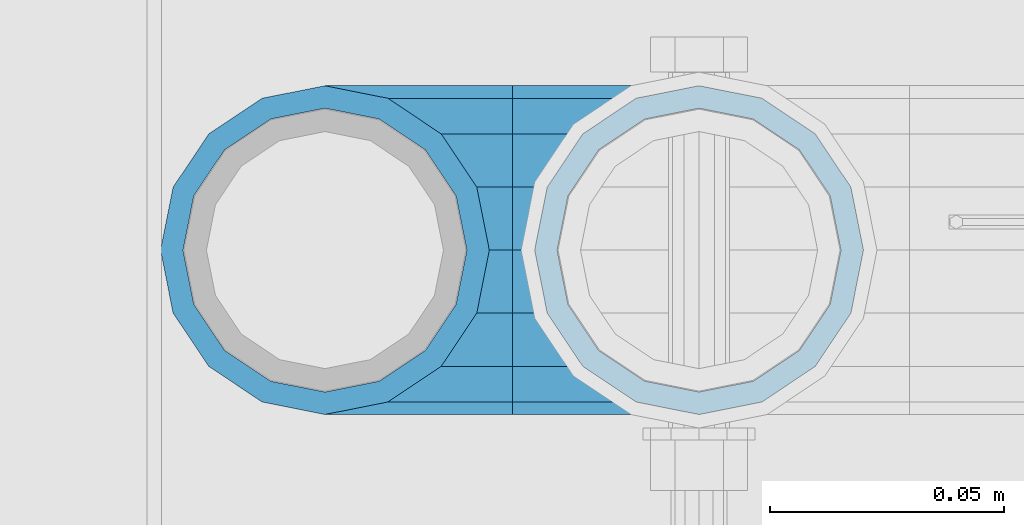
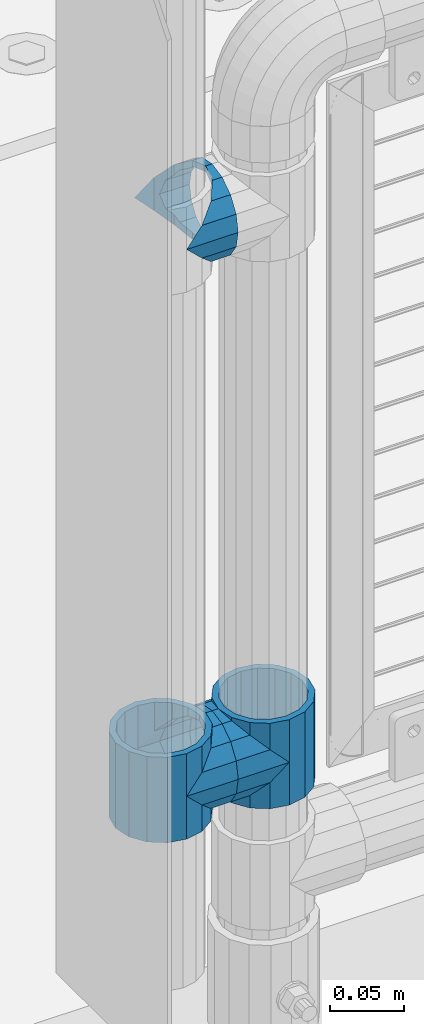
# One storey, part 133 of 219: 5 beams.
"""IFC2X3 building model written with IfcOpenShell, lengths in millimetres."""

from ifc_helpers import new_model, si_unit, frame, origin_with_axes, place, context, subcontext, project, spatial, faceted_brep, material, type_object, element, save


model = new_model("IFC2X3")

# Units and contexts
model_context = context("Model", 3, precision=1e-05, world=origin_with_axes())
body_context = subcontext(model_context, "Body", "Model", "MODEL_VIEW")
ifc_project = project(units=[si_unit("LENGTHUNIT", "METRE", prefix="MILLI"), si_unit("AREAUNIT", "SQUARE_METRE"), si_unit("VOLUMEUNIT", "CUBIC_METRE"), si_unit("MASSUNIT", "GRAM", prefix="KILO"), si_unit("TIMEUNIT", "SECOND"), si_unit("PLANEANGLEUNIT", "RADIAN"), si_unit("SOLIDANGLEUNIT", "STERADIAN"), si_unit("THERMODYNAMICTEMPERATUREUNIT", "DEGREE_CELSIUS"), si_unit("LUMINOUSINTENSITYUNIT", "LUMEN")], contexts=[model_context])

# Site, building, storey
site_placement = place(None, origin_with_axes())
site = spatial("IfcSite", under=ifc_project, at=site_placement, CompositionType="ELEMENT")
building_placement = place(site_placement, origin_with_axes())
building = spatial("IfcBuilding", under=site, at=building_placement, Name="Standard", CompositionType="ELEMENT")
storey_placement = place(building_placement, origin_with_axes())
storey = spatial("IfcBuildingStorey", under=building, at=storey_placement, Name="Undefined", CompositionType="ELEMENT", Elevation=0.0)

# Beams
ifc_material = material(Name="Misc_Undefined")
beam_type = type_object("IfcBeamType", PredefinedType="NOTDEFINED")
beam_1_placement = place(storey_placement, frame((541.0, 31664.5, 398.670000000001), z_axis=(0.0, -1.0, 0.0), x_axis=(1.0, 0.0, 0.0)))
element("IfcBeam", 1, at=beam_1_placement, inside=storey, type_object=beam_type, material=ifc_material, context=body_context, shape_type="Brep", body=[
    faceted_brep([(0.0, 0.0, -35.1500000000015), (13.4513226476338, -13.4513226476329, -32.4743655677703), (13.4513226476338, 13.4513226476329, -32.4743655677703), (32.4743655677721, 32.4743655677717, 13.4513226476338), (32.4743655677721, 26.8123795176755, 13.4513226476338), (27.1226768591096, 21.4606908090117, 21.46069080901), (24.8548033587067, 16.3810424080078, 24.8548033587067), (24.8548033587067, 24.8548033587072, 24.8548033587067), (0.0, 0.0, 35.1500000000015), (13.4513226476338, 13.4513226476329, 32.4743655677703), (13.4513226476338, -13.4513226476329, 32.4743655677703), (20.0882031229849, 11.6144421722805, 28.0397438117179), (16.6306603983739, 0.0, 30.3499999999985), (20.0882031229849, -11.6144421722805, 28.0397438117179), (24.8548033587067, -16.3810424080013, 24.8548033587067), (24.8548033587067, -24.8548033587072, 24.8548033587067), (27.1226768591096, -21.4606908090117, 21.46069080901), (32.4743655677721, -26.8123795176755, 13.4513226476338), (32.4743655677721, -32.4743655677717, 13.4513226476338), (32.8397438117172, -28.0397438117175, 11.614442172282), (35.1499999999996, -30.35, 0.0), (35.1499999999996, -35.15, 0.0), (32.4743655677721, -26.8123795176712, -13.4513226476338), (32.4743655677721, -32.4743655677717, -13.4513226476338), (32.8397438117172, -28.0397438117175, -11.614442172282), (24.8548033587067, -16.3810424080013, -24.8548033587067), (24.8548033587067, -24.8548033587072, -24.8548033587067), (27.1226768591077, -21.4606908090117, -21.46069080901), (20.0882031229739, -11.6144421722805, -28.0397438117179), (16.6306603983649, 0.0, -30.3499999999985), (20.0882031229739, 11.6144421722805, -28.0397438117179), (24.8548033587067, 16.3810424080013, -24.8548033587067), (24.8548033587067, 24.8548033587072, -24.8548033587067), (27.1226768591077, 21.4606908090117, -21.46069080901), (32.4743655677721, 26.8123795176755, -13.4513226476338), (32.4743655677721, 32.4743655677717, -13.4513226476338), (32.8397438117172, 28.0397438117175, -11.614442172282), (35.1499999999996, 30.35, 0.0), (35.1499999999996, 35.15, 0.0), (32.8397438117172, 28.0397438117175, 11.614442172282), (40.1500000000015, -35.15, 0.0), (40.1500000000015, -32.4743655677717, 13.4513226476338), (40.1500000000015, -24.8548033587072, 24.8548033587067), (40.1500000000015, -13.4513226476329, 32.4743655677703), (40.1500000000015, 0.0, 35.1500000000015), (40.1500000000015, 13.4513226476329, 32.4743655677703), (40.1500000000015, 24.8548033587072, 24.8548033587067), (40.1500000000015, 32.4743655677717, 13.4513226476338), (40.1500000000015, 35.15, 0.0), (40.1500000000015, -24.8548033587072, -24.8548033587067), (40.1500000000015, -32.4743655677717, -13.4513226476338), (40.1500000000015, -13.4513226476329, -32.4743655677703), (40.1500000000015, 0.0, -35.1500000000015), (40.1500000000015, 13.4513226476329, -32.4743655677703), (40.1500000000015, 24.8548033587072, -24.8548033587067), (40.1500000000015, 32.4743655677717, -13.4513226476338), (40.1500000000015, -21.4606908090117, 21.46069080901), (40.1500000000015, -11.6144421722805, 28.0397438117179), (40.1500000000015, 0.0, 30.3499999999985), (40.1500000000015, 11.6144421722805, 28.0397438117179), (40.1500000000015, 21.4606908090117, 21.46069080901), (40.1500000000015, 28.0397438117175, 11.614442172282), (40.1500000000015, 30.35, 0.0), (40.1500000000015, 28.0397438117175, -11.614442172282), (40.1500000000015, 21.4606908090117, -21.46069080901), (40.1500000000015, 11.6144421722805, -28.0397438117179), (40.1500000000015, 0.0, -30.3499999999985), (40.1500000000015, -11.6144421722805, -28.0397438117179), (40.1500000000015, -21.4606908090117, -21.46069080901), (40.1500000000015, -28.0397438117175, -11.614442172282), (40.1500000000015, -30.35, 0.0), (40.1500000000015, -28.0397438117175, 11.614442172282)], [[[0, 1, 2]], [[3, 4, 5, 6, 7]], [[8, 9, 10]], [[7, 6, 11, 12, 13, 14, 15, 10, 9]], [[16, 17, 18, 15, 14]], [[19, 20, 21, 18, 17]], [[22, 23, 21, 20, 24]], [[25, 26, 23, 22, 27]], [[2, 1, 26, 25, 28, 29, 30, 31, 32]], [[32, 31, 33, 34, 35]], [[35, 34, 36, 37, 38]], [[38, 37, 39, 4, 3]], [[40, 41, 18, 21]], [[41, 42, 15, 18]], [[42, 43, 10, 15]], [[43, 44, 8, 10]], [[44, 45, 9, 8]], [[45, 46, 7, 9]], [[46, 47, 3, 7]], [[47, 48, 38, 3]], [[49, 50, 23, 26]], [[51, 49, 26, 1]], [[52, 51, 1, 0]], [[53, 52, 0, 2]], [[54, 53, 2, 32]], [[55, 54, 32, 35]], [[48, 55, 35, 38]], [[50, 40, 21, 23]], [[49, 51, 52, 53, 54, 55, 48, 47, 46, 45, 44, 43, 42, 41, 40, 50], [56, 57, 58, 59, 60, 61, 62, 63, 64, 65, 66, 67, 68, 69, 70, 71]], [[63, 62, 37, 36]], [[33, 64, 63, 36, 34]], [[30, 65, 64, 33, 31]], [[66, 65, 30, 29]], [[67, 66, 29, 28]], [[68, 67, 28, 25, 27]], [[69, 68, 27, 22, 24]], [[70, 69, 24, 20]], [[71, 70, 20, 19]], [[16, 56, 71, 19, 17]], [[13, 57, 56, 16, 14]], [[58, 57, 13, 12]], [[59, 58, 12, 11]], [[60, 59, 11, 6, 5]], [[61, 60, 5, 4, 39]], [[62, 61, 39, 37]]]),
])
beam_2_placement = place(storey_placement, frame((621.0, 31664.5, 398.670000000001), z_axis=(0.0, 1.0, 0.0), x_axis=(-1.0, 0.0, 0.0)))
element("IfcBeam", 2, at=beam_2_placement, inside=storey, type_object=beam_type, material=ifc_material, context=body_context, shape_type="Brep", body=[
    faceted_brep([(0.0, 0.0, -35.1500000000015), (13.4513226476338, -13.4513226476329, -32.4743655677703), (13.4513226476338, 13.4513226476329, -32.4743655677703), (27.1226768591096, -21.4606908090117, 21.46069080901), (32.4743655677721, -26.8123795176755, 13.4513226476338), (32.4743655677721, -32.4743655677717, 13.4513226476338), (24.8548033587067, -24.8548033587072, 24.8548033587067), (24.8548033587067, -16.3810424080013, 24.8548033587067), (32.8397438117172, -28.0397438117175, 11.614442172282), (35.1499999999996, -30.35, 0.0), (35.1499999999996, -35.15, 0.0), (32.4743655677721, -26.8123795176712, -13.4513226476338), (32.4743655677721, -32.4743655677717, -13.4513226476338), (32.8397438117172, -28.0397438117175, -11.614442172282), (24.8548033587067, -16.3810424080013, -24.8548033587067), (24.8548033587067, -24.8548033587072, -24.8548033587067), (27.1226768591077, -21.4606908090117, -21.46069080901), (20.0882031229739, -11.6144421722805, -28.0397438117179), (16.6306603983649, 0.0, -30.3499999999985), (20.0882031229739, 11.6144421722805, -28.0397438117179), (24.8548033587067, 16.3810424080013, -24.8548033587067), (24.8548033587067, 24.8548033587072, -24.8548033587067), (27.1226768591077, 21.4606908090117, -21.46069080901), (32.4743655677721, 26.8123795176755, -13.4513226476338), (32.4743655677721, 32.4743655677717, -13.4513226476338), (32.8397438117172, 28.0397438117175, -11.614442172282), (35.1499999999996, 30.35, 0.0), (35.1499999999996, 35.15, 0.0), (32.8397438117172, 28.0397438117175, 11.614442172282), (32.4743655677721, 26.8123795176755, 13.4513226476338), (32.4743655677721, 32.4743655677717, 13.4513226476338), (27.1226768591096, 21.4606908090117, 21.46069080901), (24.8548033587067, 16.3810424080078, 24.8548033587067), (24.8548033587067, 24.8548033587072, 24.8548033587067), (0.0, 0.0, 35.1500000000015), (13.4513226476338, 13.4513226476329, 32.4743655677703), (13.4513226476338, -13.4513226476329, 32.4743655677703), (20.0882031229849, 11.6144421722805, 28.0397438117179), (16.6306603983739, 0.0, 30.3499999999985), (20.0882031229849, -11.6144421722805, 28.0397438117179), (40.1500000000015, -35.15, 0.0), (40.1500000000015, -32.4743655677717, 13.4513226476338), (40.1500000000015, -24.8548033587072, 24.8548033587067), (40.1500000000015, -13.4513226476329, 32.4743655677703), (40.1500000000015, 0.0, 35.1500000000015), (40.1500000000015, -24.8548033587072, -24.8548033587067), (40.1500000000015, -32.4743655677717, -13.4513226476338), (40.1500000000015, -13.4513226476329, -32.4743655677703), (40.1500000000015, 0.0, -35.1500000000015), (40.1500000000015, 13.4513226476329, -32.4743655677703), (40.1500000000015, 24.8548033587072, -24.8548033587067), (40.1500000000015, 32.4743655677717, -13.4513226476338), (40.1500000000015, 35.15, 0.0), (40.1500000000015, 32.4743655677717, 13.4513226476338), (40.1500000000015, 24.8548033587072, 24.8548033587067), (40.1500000000015, 13.4513226476329, 32.4743655677703), (40.1500000000015, -21.4606908090117, 21.46069080901), (40.1500000000015, -11.6144421722805, 28.0397438117179), (40.1500000000015, 0.0, 30.3499999999985), (40.1500000000015, 11.6144421722805, 28.0397438117179), (40.1500000000015, 21.4606908090117, 21.46069080901), (40.1500000000015, 28.0397438117175, 11.614442172282), (40.1500000000015, 30.35, 0.0), (40.1500000000015, 28.0397438117175, -11.614442172282), (40.1500000000015, 21.4606908090117, -21.46069080901), (40.1500000000015, 11.6144421722805, -28.0397438117179), (40.1500000000015, 0.0, -30.3499999999985), (40.1500000000015, -11.6144421722805, -28.0397438117179), (40.1500000000015, -21.4606908090117, -21.46069080901), (40.1500000000015, -28.0397438117175, -11.614442172282), (40.1500000000015, -30.35, 0.0), (40.1500000000015, -28.0397438117175, 11.614442172282)], [[[0, 1, 2]], [[3, 4, 5, 6, 7]], [[8, 9, 10, 5, 4]], [[11, 12, 10, 9, 13]], [[14, 15, 12, 11, 16]], [[2, 1, 15, 14, 17, 18, 19, 20, 21]], [[21, 20, 22, 23, 24]], [[24, 23, 25, 26, 27]], [[27, 26, 28, 29, 30]], [[30, 29, 31, 32, 33]], [[34, 35, 36]], [[33, 32, 37, 38, 39, 7, 6, 36, 35]], [[40, 41, 5, 10]], [[41, 42, 6, 5]], [[42, 43, 36, 6]], [[43, 44, 34, 36]], [[45, 46, 12, 15]], [[47, 45, 15, 1]], [[48, 47, 1, 0]], [[49, 48, 0, 2]], [[50, 49, 2, 21]], [[51, 50, 21, 24]], [[52, 51, 24, 27]], [[53, 52, 27, 30]], [[54, 53, 30, 33]], [[55, 54, 33, 35]], [[44, 55, 35, 34]], [[46, 40, 10, 12]], [[45, 47, 48, 49, 50, 51, 52, 53, 54, 55, 44, 43, 42, 41, 40, 46], [56, 57, 58, 59, 60, 61, 62, 63, 64, 65, 66, 67, 68, 69, 70, 71]], [[59, 58, 38, 37]], [[60, 59, 37, 32, 31]], [[61, 60, 31, 29, 28]], [[62, 61, 28, 26]], [[63, 62, 26, 25]], [[22, 64, 63, 25, 23]], [[19, 65, 64, 22, 20]], [[66, 65, 19, 18]], [[67, 66, 18, 17]], [[68, 67, 17, 14, 16]], [[69, 68, 16, 11, 13]], [[70, 69, 13, 9]], [[71, 70, 9, 8]], [[3, 56, 71, 8, 4]], [[39, 57, 56, 3, 7]], [[58, 57, 39, 38]]]),
])
beam_3_placement = place(storey_placement, frame((541.0, 31664.5, 433.820000000001), z_axis=(-1.0, 0.0, 0.0), x_axis=(0.0, 0.0, -1.0)))
element("IfcBeam", 3, at=beam_3_placement, inside=storey, type_object=beam_type, material=ifc_material, context=body_context, shape_type="Brep", body=[
    faceted_brep([(13.6893091909879, -21.46069080901, -21.4606908090118), (13.6893091909879, -21.46069080901, -27.1226768591077), (8.33762048232455, -13.4513226476338, -32.4743655677721), (7.11025618828211, -11.614442172282, -32.839743811719), (7.11025618828211, -11.614442172282, -28.0397438117179), (23.5355578277191, -28.0397438117179, -11.6144421722802), (23.5355578277191, -28.0397438117179, -20.0882031229739), (18.7689575919921, -24.8548033587067, -24.8548033587067), (35.1499999999996, -30.35, 0.0), (35.1499999999996, -30.3499999999985, -16.6306603983649), (46.7644421722801, -28.0397438117179, -11.6144421722802), (46.7644421722801, -28.0397438117179, -20.0882031229739), (56.6106908090114, -21.46069080901, -21.4606908090118), (56.6106908090114, -21.46069080901, -27.1226768591077), (51.5310424080006, -24.8548033587067, -24.8548033587067), (63.1897438117172, -11.614442172282, -28.0397438117179), (63.1897438117172, -11.614442172282, -32.839743811719), (61.9623795176747, -13.4513226476338, -32.4743655677721), (65.4999999999997, 0.0, -30.3500000000004), (65.4999999999997, 0.0, -35.1499999999996), (63.1897438117172, 11.614442172282, -28.0397438117179), (63.1897438117172, 11.614442172282, -32.8397438117172), (56.6106908090114, 21.46069080901, -21.4606908090118), (56.6106908090114, 21.46069080901, -27.1226768591096), (61.9623795176703, 13.4513226476338, -32.4743655677721), (46.7644421722801, 28.0397438117179, -11.6144421722802), (46.7644421722801, 28.0397438117179, -20.0882031229849), (51.5310424080006, 24.8548033587067, -24.8548033587067), (35.1499999999996, 30.35, 0.0), (35.1499999999996, 30.3499999999985, -16.6306603983739), (23.5355578277192, 28.0397438117179, -11.6144421722802), (23.5355578277192, 28.0397438117179, -20.0882031229849), (13.6893091909879, 21.46069080901, -21.4606908090118), (13.6893091909879, 21.46069080901, -27.1226768591096), (18.7689575919987, 24.8548033587067, -24.8548033587067), (7.11025618828211, 11.614442172282, -28.0397438117179), (7.11025618828211, 11.614442172282, -32.8397438117172), (8.33762048232455, 13.4513226476338, -32.4743655677721), (4.79999999999961, 0.0, -30.3500000000004), (4.79999999999961, 0.0, -35.1499999999996), (0.0, 21.46069080901, 21.4606908090118), (0.0, 28.0397438117179, 11.6144421722802), (70.2999999999993, 28.0397438117179, 11.6144421722802), (70.2999999999993, 21.46069080901, 21.4606908090118), (0.0, 11.614442172282, 28.0397438117179), (70.2999999999993, 11.614442172282, 28.0397438117179), (0.0, 0.0, 30.3500000000004), (70.2999999999993, 0.0, 30.3500000000004), (0.0, -11.614442172282, 28.0397438117179), (70.2999999999993, -11.614442172282, 28.0397438117179), (0.0, -21.46069080901, 21.4606908090118), (70.2999999999993, -21.46069080901, 21.4606908090118), (0.0, -28.0397438117179, 11.6144421722802), (70.2999999999993, -28.0397438117179, 11.6144421722802), (0.0, -24.8548033587067, -24.8548033587067), (0.0, -13.4513226476338, -32.4743655677721), (0.0, 0.0, -35.1500000000015), (0.0, -32.4743655677703, 13.4513226476338), (0.0, -35.1500000000015, 0.0), (70.2999999999993, -35.1500000000015, 0.0), (70.2999999999993, -32.4743655677703, 13.4513226476338), (0.0, -24.8548033587067, 24.8548033587067), (70.2999999999993, -24.8548033587067, 24.8548033587067), (0.0, -13.4513226476338, 32.4743655677721), (70.2999999999993, -13.4513226476338, 32.4743655677721), (0.0, 0.0, 35.1500000000015), (70.2999999999993, 0.0, 35.1499999999996), (0.0, 13.4513226476338, 32.4743655677721), (70.2999999999993, 13.4513226476338, 32.4743655677721), (0.0, 24.8548033587067, 24.8548033587067), (70.2999999999993, 24.8548033587067, 24.8548033587067), (0.0, 32.4743655677703, 13.4513226476338), (70.2999999999993, 32.4743655677703, 13.4513226476338), (0.0, 35.1500000000015, 0.0), (70.2999999999993, 35.1500000000015, 0.0), (0.0, 32.4743655677703, -13.4513226476338), (70.2999999999993, 32.4743655677703, -13.4513226476338), (70.2999999999993, -13.4513226476338, -32.4743655677721), (70.2999999999993, -24.8548033587067, -24.8548033587067), (70.2999999999993, 0.0, -35.1499999999996), (70.2999999999993, 13.4513226476338, -32.4743655677721), (70.2999999999993, 24.8548033587067, -24.8548033587067), (0.0, 24.8548033587067, -24.8548033587067), (0.0, 13.4513226476338, -32.4743655677721), (70.2999999999993, -32.4743655677703, -13.4513226476338), (0.0, -32.4743655677703, -13.4513226476338), (0.0, -28.0397438117179, -11.6144421722802), (0.0, -21.46069080901, -21.4606908090118), (0.0, -11.614442172282, -28.0397438117179), (0.0, 0.0, -30.3500000000004), (0.0, 11.614442172282, -28.0397438117179), (0.0, 21.46069080901, -21.4606908090118), (0.0, 28.0397438117179, -11.6144421722802), (0.0, 30.3499999999985, 0.0), (0.0, -30.3499999999985, 0.0), (70.2999999999993, 30.3499999999985, 0.0), (70.2999999999993, 28.0397438117179, -11.6144421722802), (70.2999999999993, 21.46069080901, -21.4606908090118), (70.2999999999993, 11.614442172282, -28.0397438117179), (70.2999999999993, 0.0, -30.3500000000004), (70.2999999999993, -11.614442172282, -28.0397438117179), (70.2999999999993, -21.46069080901, -21.4606908090118), (70.2999999999993, -28.0397438117179, -11.6144421722802), (70.2999999999993, -30.3499999999985, 0.0)], [[[0, 1, 2, 3, 4]], [[5, 6, 7, 1, 0]], [[8, 9, 6, 5]], [[10, 11, 9, 8]], [[12, 13, 14, 11, 10]], [[15, 16, 17, 13, 12]], [[18, 19, 16, 15]], [[20, 21, 19, 18]], [[22, 23, 24, 21, 20]], [[25, 26, 27, 23, 22]], [[28, 29, 26, 25]], [[30, 31, 29, 28]], [[32, 33, 34, 31, 30]], [[35, 36, 37, 33, 32]], [[38, 39, 36, 35]], [[4, 3, 39, 38]], [[40, 41, 42, 43]], [[44, 40, 43, 45]], [[46, 44, 45, 47]], [[48, 46, 47, 49]], [[50, 48, 49, 51]], [[52, 50, 51, 53]], [[54, 55, 2, 1, 7]], [[55, 56, 39, 3, 2]], [[57, 58, 59, 60]], [[61, 57, 60, 62]], [[63, 61, 62, 64]], [[65, 63, 64, 66]], [[67, 65, 66, 68]], [[69, 67, 68, 70]], [[71, 69, 70, 72]], [[73, 71, 72, 74]], [[75, 73, 74, 76]], [[17, 77, 78, 14, 13]], [[19, 79, 77, 17, 16]], [[80, 79, 19, 21, 24]], [[81, 80, 24, 23, 27]], [[34, 82, 75, 76, 81, 27, 26, 29, 31]], [[37, 83, 82, 34, 33]], [[39, 56, 83, 37, 36]], [[14, 78, 84, 85, 54, 7, 6, 9, 11]], [[58, 85, 84, 59]], [[57, 61, 63, 65, 67, 69, 71, 73, 75, 82, 83, 56, 55, 54, 85, 58], [86, 87, 88, 89, 90, 91, 92, 93, 41, 40, 44, 46, 48, 50, 52, 94]], [[90, 89, 38, 35]], [[91, 90, 35, 32]], [[92, 91, 32, 30]], [[93, 92, 30, 28]], [[41, 93, 28, 95, 42]], [[96, 95, 28, 25]], [[97, 96, 25, 22]], [[98, 97, 22, 20]], [[99, 98, 20, 18]], [[100, 99, 18, 15]], [[101, 100, 15, 12]], [[102, 101, 12, 10]], [[103, 102, 10, 8]], [[78, 77, 79, 80, 81, 76, 74, 72, 70, 68, 66, 64, 62, 60, 59, 84], [51, 49, 47, 45, 43, 42, 95, 96, 97, 98, 99, 100, 101, 102, 103, 53]], [[8, 94, 52, 53, 103]], [[86, 94, 8, 5]], [[87, 86, 5, 0]], [[88, 87, 0, 4]], [[89, 88, 4, 38]]]),
])
beam_4_placement = place(storey_placement, frame((621.0, 31664.5, 433.820000000001), z_axis=(1.0, 0.0, 0.0), x_axis=(0.0, 0.0, -1.0)))
element("IfcBeam", 4, at=beam_4_placement, inside=storey, type_object=beam_type, material=ifc_material, context=body_context, shape_type="Brep", body=[
    faceted_brep([(46.7644421722801, 28.0397438117179, -11.6144421722802), (46.7644421722801, 28.0397438117179, -20.0882031229849), (51.5310424080006, 24.8548033587067, -24.8548033587067), (56.6106908090114, 21.46069080901, -27.1226768591096), (56.6106908090114, 21.46069080901, -21.4606908090118), (61.9623795176703, 13.4513226476338, -32.4743655677721), (63.1897438117172, 11.614442172282, -32.8397438117172), (63.1897438117172, 11.614442172282, -28.0397438117179), (65.4999999999997, 0.0, -35.1499999999996), (65.4999999999997, 0.0, -30.3500000000004), (63.1897438117172, -11.614442172282, -32.839743811719), (63.1897438117172, -11.614442172282, -28.0397438117179), (61.9623795176747, -13.4513226476338, -32.4743655677721), (56.6106908090114, -21.46069080901, -27.1226768591077), (56.6106908090114, -21.46069080901, -21.4606908090118), (51.5310424080006, -24.8548033587067, -24.8548033587067), (46.7644421722801, -28.0397438117179, -20.0882031229739), (46.7644421722801, -28.0397438117179, -11.6144421722802), (35.1499999999996, -30.3499999999985, -16.6306603983649), (35.1499999999996, -30.35, 0.0), (23.5355578277191, -28.0397438117179, -20.0882031229739), (23.5355578277191, -28.0397438117179, -11.6144421722802), (18.7689575919921, -24.8548033587067, -24.8548033587067), (13.6893091909879, -21.46069080901, -27.1226768591077), (13.6893091909879, -21.46069080901, -21.4606908090118), (8.33762048232455, -13.4513226476338, -32.4743655677721), (7.11025618828211, -11.614442172282, -32.839743811719), (7.11025618828211, -11.614442172282, -28.0397438117179), (4.79999999999961, 0.0, -35.1499999999996), (4.79999999999961, 0.0, -30.3500000000004), (7.11025618828211, 11.614442172282, -32.8397438117172), (7.11025618828211, 11.614442172282, -28.0397438117179), (8.33762048232455, 13.4513226476338, -32.4743655677721), (13.6893091909879, 21.46069080901, -27.1226768591096), (13.6893091909879, 21.46069080901, -21.4606908090118), (18.7689575919987, 24.8548033587067, -24.8548033587067), (23.5355578277192, 28.0397438117179, -20.0882031229849), (23.5355578277192, 28.0397438117179, -11.6144421722802), (35.1499999999996, 30.3499999999985, -16.6306603983739), (35.1499999999996, 30.35, 0.0), (0.0, 32.4743655677703, -13.4513226476338), (0.0, 35.1500000000015, 0.0), (70.2999999999993, 35.1500000000015, 0.0), (70.2999999999993, 32.4743655677703, -13.4513226476338), (0.0, 32.4743655677703, 13.4513226476338), (70.2999999999993, 32.4743655677703, 13.4513226476338), (0.0, 24.8548033587067, 24.8548033587067), (70.2999999999993, 24.8548033587067, 24.8548033587067), (0.0, 13.4513226476338, 32.4743655677721), (70.2999999999993, 13.4513226476338, 32.4743655677721), (0.0, 0.0, 35.1500000000015), (70.2999999999993, 0.0, 35.1499999999996), (0.0, -13.4513226476338, 32.4743655677721), (70.2999999999993, -13.4513226476338, 32.4743655677721), (0.0, -24.8548033587067, 24.8548033587067), (70.2999999999993, -24.8548033587067, 24.8548033587067), (0.0, -32.4743655677703, 13.4513226476338), (70.2999999999993, -32.4743655677703, 13.4513226476338), (0.0, -35.1500000000015, 0.0), (70.2999999999993, -35.1500000000015, 0.0), (70.2999999999993, -30.3499999999985, 0.0), (70.2999999999993, -28.0397438117179, -11.6144421722802), (70.2999999999993, -21.46069080901, -21.4606908090118), (70.2999999999993, -11.614442172282, -28.0397438117179), (70.2999999999993, 0.0, -30.3500000000004), (70.2999999999993, 11.614442172282, -28.0397438117179), (70.2999999999993, 21.46069080901, -21.4606908090118), (70.2999999999993, 28.0397438117179, -11.6144421722802), (0.0, -28.0397438117179, -11.6144421722802), (0.0, -30.3499999999985, 0.0), (0.0, -21.46069080901, -21.4606908090118), (0.0, -11.614442172282, -28.0397438117179), (0.0, 0.0, -30.3500000000004), (0.0, 11.614442172282, -28.0397438117179), (0.0, 21.46069080901, -21.4606908090118), (0.0, 28.0397438117179, -11.6144421722802), (0.0, 30.3499999999985, 0.0), (70.2999999999993, 30.3499999999985, 0.0), (0.0, 28.0397438117179, 11.6144421722802), (70.2999999999993, 28.0397438117179, 11.6144421722802), (0.0, 21.46069080901, 21.4606908090118), (70.2999999999993, 21.46069080901, 21.4606908090118), (0.0, 11.614442172282, 28.0397438117179), (70.2999999999993, 11.614442172282, 28.0397438117179), (0.0, 0.0, 30.3500000000004), (70.2999999999993, 0.0, 30.3500000000004), (0.0, -11.614442172282, 28.0397438117179), (70.2999999999993, -11.614442172282, 28.0397438117179), (0.0, -21.46069080901, 21.4606908090118), (70.2999999999993, -21.46069080901, 21.4606908090118), (0.0, -28.0397438117179, 11.6144421722802), (70.2999999999993, -28.0397438117179, 11.6144421722802), (70.2999999999993, -24.8548033587067, -24.8548033587067), (70.2999999999993, -13.4513226476338, -32.4743655677721), (70.2999999999993, 0.0, -35.1499999999996), (70.2999999999993, 13.4513226476338, -32.4743655677721), (70.2999999999993, 24.8548033587067, -24.8548033587067), (70.2999999999993, -32.4743655677703, -13.4513226476338), (0.0, -32.4743655677703, -13.4513226476338), (0.0, 24.8548033587067, -24.8548033587067), (0.0, 13.4513226476338, -32.4743655677721), (0.0, 0.0, -35.1500000000015), (0.0, -13.4513226476338, -32.4743655677721), (0.0, -24.8548033587067, -24.8548033587067)], [[[0, 1, 2, 3, 4]], [[4, 3, 5, 6, 7]], [[7, 6, 8, 9]], [[9, 8, 10, 11]], [[11, 10, 12, 13, 14]], [[14, 13, 15, 16, 17]], [[17, 16, 18, 19]], [[19, 18, 20, 21]], [[21, 20, 22, 23, 24]], [[24, 23, 25, 26, 27]], [[27, 26, 28, 29]], [[29, 28, 30, 31]], [[31, 30, 32, 33, 34]], [[34, 33, 35, 36, 37]], [[37, 36, 38, 39]], [[39, 38, 1, 0]], [[40, 41, 42, 43]], [[41, 44, 45, 42]], [[44, 46, 47, 45]], [[46, 48, 49, 47]], [[48, 50, 51, 49]], [[50, 52, 53, 51]], [[52, 54, 55, 53]], [[54, 56, 57, 55]], [[56, 58, 59, 57]], [[60, 61, 17, 19]], [[61, 62, 14, 17]], [[62, 63, 11, 14]], [[63, 64, 9, 11]], [[64, 65, 7, 9]], [[65, 66, 4, 7]], [[66, 67, 0, 4]], [[68, 69, 19, 21]], [[70, 68, 21, 24]], [[71, 70, 24, 27]], [[72, 71, 27, 29]], [[73, 72, 29, 31]], [[74, 73, 31, 34]], [[75, 74, 34, 37]], [[76, 75, 37, 39]], [[67, 77, 39, 0]], [[78, 76, 39, 77, 79]], [[80, 78, 79, 81]], [[82, 80, 81, 83]], [[84, 82, 83, 85]], [[86, 84, 85, 87]], [[88, 86, 87, 89]], [[90, 88, 89, 91]], [[19, 69, 90, 91, 60]], [[92, 93, 94, 95, 96, 43, 42, 45, 47, 49, 51, 53, 55, 57, 59, 97], [89, 87, 85, 83, 81, 79, 77, 67, 66, 65, 64, 63, 62, 61, 60, 91]], [[58, 98, 97, 59]], [[56, 54, 52, 50, 48, 46, 44, 41, 40, 99, 100, 101, 102, 103, 98, 58], [68, 70, 71, 72, 73, 74, 75, 76, 78, 80, 82, 84, 86, 88, 90, 69]], [[32, 100, 99, 35, 33]], [[28, 101, 100, 32, 30]], [[102, 101, 28, 26, 25]], [[103, 102, 25, 23, 22]], [[15, 92, 97, 98, 103, 22, 20, 18, 16]], [[12, 93, 92, 15, 13]], [[8, 94, 93, 12, 10]], [[95, 94, 8, 6, 5]], [[96, 95, 5, 3, 2]], [[35, 99, 40, 43, 96, 2, 1, 38, 36]]]),
])
beam_5_placement = place(storey_placement, frame((541.0, 31664.5, 848.670000000001), z_axis=(0.0, -1.0, 0.0), x_axis=(1.0, 0.0, 0.0)))
element("IfcBeam", 5, at=beam_5_placement, inside=storey, type_object=beam_type, material=ifc_material, context=body_context, shape_type="Brep", body=[
    faceted_brep([(0.0, 0.0, -35.1500000000015), (13.4513226476338, -13.4513226476329, -32.4743655677703), (13.4513226476338, 13.4513226476329, -32.4743655677703), (32.4743655677721, 32.4743655677717, 13.4513226476338), (32.4743655677721, 26.8123795176755, 13.4513226476338), (27.1226768591096, 21.4606908090117, 21.46069080901), (24.8548033587067, 16.3810424080078, 24.8548033587067), (24.8548033587067, 24.8548033587072, 24.8548033587067), (0.0, 0.0, 35.1500000000015), (13.4513226476338, 13.4513226476329, 32.4743655677703), (13.4513226476338, -13.4513226476329, 32.4743655677703), (20.0882031229849, 11.6144421722805, 28.0397438117179), (16.6306603983739, 0.0, 30.3499999999985), (20.0882031229849, -11.6144421722805, 28.0397438117179), (24.8548033587067, -16.3810424080013, 24.8548033587067), (24.8548033587067, -24.8548033587072, 24.8548033587067), (27.1226768591096, -21.4606908090117, 21.46069080901), (32.4743655677721, -26.8123795176755, 13.4513226476338), (32.4743655677721, -32.4743655677717, 13.4513226476338), (32.8397438117172, -28.0397438117175, 11.614442172282), (35.1499999999996, -30.35, 0.0), (35.1499999999996, -35.15, 0.0), (32.4743655677721, -26.8123795176712, -13.4513226476338), (32.4743655677721, -32.4743655677717, -13.4513226476338), (32.8397438117172, -28.0397438117175, -11.614442172282), (24.8548033587067, -16.3810424080013, -24.8548033587067), (24.8548033587067, -24.8548033587072, -24.8548033587067), (27.1226768591077, -21.4606908090117, -21.46069080901), (20.0882031229739, -11.6144421722805, -28.0397438117179), (16.6306603983649, 0.0, -30.3499999999985), (20.0882031229739, 11.6144421722805, -28.0397438117179), (24.8548033587067, 16.3810424080013, -24.8548033587067), (24.8548033587067, 24.8548033587072, -24.8548033587067), (27.1226768591077, 21.4606908090117, -21.46069080901), (32.4743655677721, 26.8123795176755, -13.4513226476338), (32.4743655677721, 32.4743655677717, -13.4513226476338), (32.8397438117172, 28.0397438117175, -11.614442172282), (35.1499999999996, 30.35, 0.0), (35.1499999999996, 35.15, 0.0), (32.8397438117172, 28.0397438117175, 11.614442172282), (40.1500000000015, -35.15, 0.0), (40.1500000000015, -32.4743655677717, 13.4513226476338), (40.1500000000015, -24.8548033587072, 24.8548033587067), (40.1500000000015, -13.4513226476329, 32.4743655677703), (40.1500000000015, 0.0, 35.1500000000015), (40.1500000000015, 13.4513226476329, 32.4743655677703), (40.1500000000015, 24.8548033587072, 24.8548033587067), (40.1500000000015, 32.4743655677717, 13.4513226476338), (40.1500000000015, 35.15, 0.0), (40.1500000000015, -24.8548033587072, -24.8548033587067), (40.1500000000015, -32.4743655677717, -13.4513226476338), (40.1500000000015, -13.4513226476329, -32.4743655677703), (40.1500000000015, 0.0, -35.1500000000015), (40.1500000000015, 13.4513226476329, -32.4743655677703), (40.1500000000015, 24.8548033587072, -24.8548033587067), (40.1500000000015, 32.4743655677717, -13.4513226476338), (40.1500000000015, -21.4606908090117, 21.46069080901), (40.1500000000015, -11.6144421722805, 28.0397438117179), (40.1500000000015, 0.0, 30.3499999999985), (40.1500000000015, 11.6144421722805, 28.0397438117179), (40.1500000000015, 21.4606908090117, 21.46069080901), (40.1500000000015, 28.0397438117175, 11.614442172282), (40.1500000000015, 30.35, 0.0), (40.1500000000015, 28.0397438117175, -11.614442172282), (40.1500000000015, 21.4606908090117, -21.46069080901), (40.1500000000015, 11.6144421722805, -28.0397438117179), (40.1500000000015, 0.0, -30.3499999999985), (40.1500000000015, -11.6144421722805, -28.0397438117179), (40.1500000000015, -21.4606908090117, -21.46069080901), (40.1500000000015, -28.0397438117175, -11.614442172282), (40.1500000000015, -30.35, 0.0), (40.1500000000015, -28.0397438117175, 11.614442172282)], [[[0, 1, 2]], [[3, 4, 5, 6, 7]], [[8, 9, 10]], [[7, 6, 11, 12, 13, 14, 15, 10, 9]], [[16, 17, 18, 15, 14]], [[19, 20, 21, 18, 17]], [[22, 23, 21, 20, 24]], [[25, 26, 23, 22, 27]], [[2, 1, 26, 25, 28, 29, 30, 31, 32]], [[32, 31, 33, 34, 35]], [[35, 34, 36, 37, 38]], [[38, 37, 39, 4, 3]], [[40, 41, 18, 21]], [[41, 42, 15, 18]], [[42, 43, 10, 15]], [[43, 44, 8, 10]], [[44, 45, 9, 8]], [[45, 46, 7, 9]], [[46, 47, 3, 7]], [[47, 48, 38, 3]], [[49, 50, 23, 26]], [[51, 49, 26, 1]], [[52, 51, 1, 0]], [[53, 52, 0, 2]], [[54, 53, 2, 32]], [[55, 54, 32, 35]], [[48, 55, 35, 38]], [[50, 40, 21, 23]], [[49, 51, 52, 53, 54, 55, 48, 47, 46, 45, 44, 43, 42, 41, 40, 50], [56, 57, 58, 59, 60, 61, 62, 63, 64, 65, 66, 67, 68, 69, 70, 71]], [[63, 62, 37, 36]], [[33, 64, 63, 36, 34]], [[30, 65, 64, 33, 31]], [[66, 65, 30, 29]], [[67, 66, 29, 28]], [[68, 67, 28, 25, 27]], [[69, 68, 27, 22, 24]], [[70, 69, 24, 20]], [[71, 70, 20, 19]], [[16, 56, 71, 19, 17]], [[13, 57, 56, 16, 14]], [[58, 57, 13, 12]], [[59, 58, 12, 11]], [[60, 59, 11, 6, 5]], [[61, 60, 5, 4, 39]], [[62, 61, 39, 37]]]),
])

save(model, "model.ifc")
